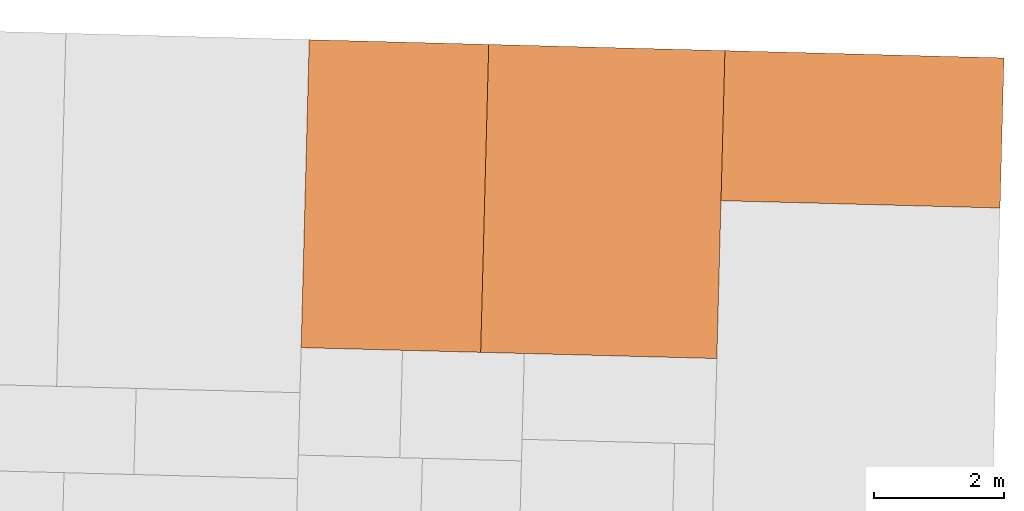
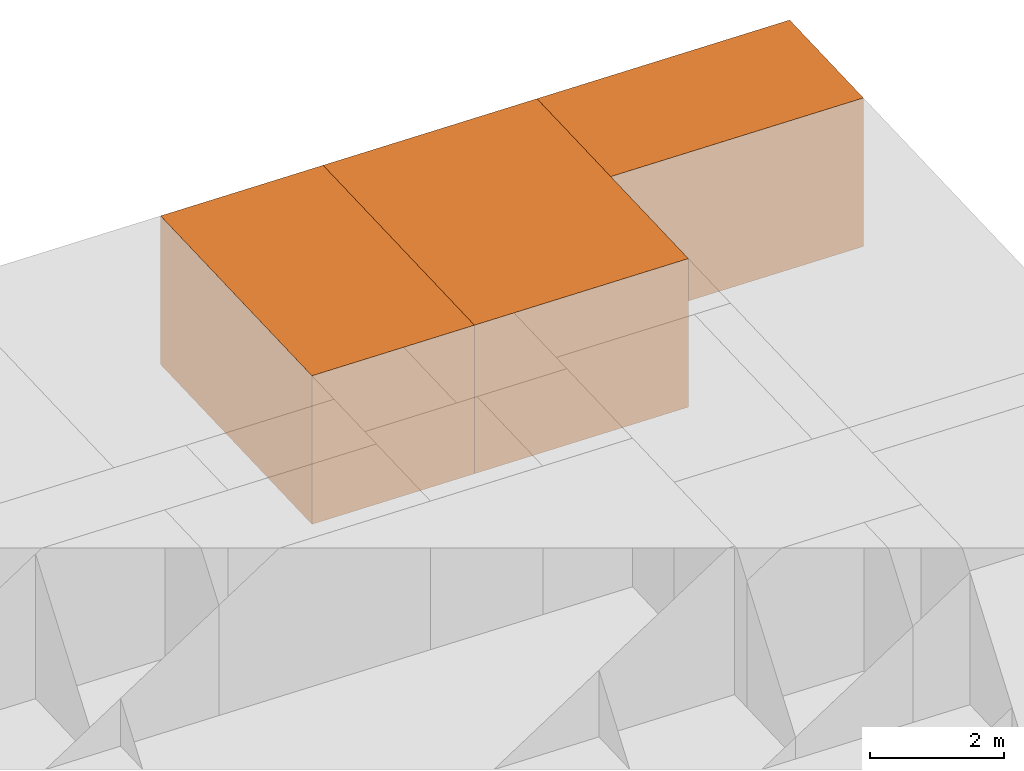
# One storey, part 2 of 2: 3 proxies.
"""IFC2X3 building model written with IfcOpenShell, lengths in metres."""

from ifc_helpers import new_model, entity, si_unit, converted_unit, derived_unit, direction, frame, origin, origin_2d_with_axis, place, context, subcontext, project, spatial, rectangle, extrude, source, transform, mapped, material, type_object, type_shapes, element, save


model = new_model("IFC2X3")

# Units and contexts
model_context = context("Model", 3, precision=1e-05, world=origin(), true_north=direction((-0.999656054706472, -0.0262254130318397)))
body_context = subcontext(model_context, "Body", "Model", "MODEL_VIEW")
ifc_project = project(units=[si_unit("LENGTHUNIT", "METRE"), si_unit("AREAUNIT", "SQUARE_METRE"), si_unit("VOLUMEUNIT", "CUBIC_METRE"), converted_unit("PLANEANGLEUNIT", "DEGREE", entity("IfcRatioMeasure", 0.0174532925199433), si_unit("PLANEANGLEUNIT", "RADIAN"), dimensions=[0, 0, 0, 0, 0, 0, 0]), si_unit("MASSUNIT", "GRAM", prefix="KILO"), derived_unit("MASSDENSITYUNIT", [(si_unit("MASSUNIT", "GRAM", prefix="KILO"), 1), (si_unit("LENGTHUNIT", "METRE"), -3)]), si_unit("TIMEUNIT", "SECOND"), si_unit("FREQUENCYUNIT", "HERTZ"), si_unit("THERMODYNAMICTEMPERATUREUNIT", "DEGREE_CELSIUS"), derived_unit("THERMALTRANSMITTANCEUNIT", [(si_unit("MASSUNIT", "GRAM", prefix="KILO"), 1), (si_unit("THERMODYNAMICTEMPERATUREUNIT", "KELVIN"), -1), (si_unit("TIMEUNIT", "SECOND"), -3)]), derived_unit("VOLUMETRICFLOWRATEUNIT", [(si_unit("LENGTHUNIT", "METRE"), 3), (si_unit("TIMEUNIT", "SECOND"), -1)]), si_unit("ELECTRICCURRENTUNIT", "AMPERE"), si_unit("ELECTRICVOLTAGEUNIT", "VOLT"), si_unit("POWERUNIT", "WATT"), si_unit("FORCEUNIT", "NEWTON", prefix="KILO"), si_unit("ILLUMINANCEUNIT", "LUX"), si_unit("LUMINOUSFLUXUNIT", "LUMEN"), si_unit("LUMINOUSINTENSITYUNIT", "CANDELA"), derived_unit("USERDEFINED", [(si_unit("MASSUNIT", "GRAM", prefix="KILO"), -1), (si_unit("LENGTHUNIT", "METRE"), -2), (si_unit("TIMEUNIT", "SECOND"), 3), (si_unit("LUMINOUSFLUXUNIT", "LUMEN"), 1)]), derived_unit("LINEARVELOCITYUNIT", [(si_unit("LENGTHUNIT", "METRE"), 1), (si_unit("TIMEUNIT", "SECOND"), -1)]), si_unit("PRESSUREUNIT", "PASCAL"), derived_unit("USERDEFINED", [(si_unit("LENGTHUNIT", "METRE"), -2), (si_unit("MASSUNIT", "GRAM", prefix="KILO"), 1), (si_unit("TIMEUNIT", "SECOND"), -2)])], contexts=[model_context])

# Site, building, storey
site_placement = place(None, frame((0.0, 0.0, 0.0), z_axis=(0.0, 0.0, 1.0), x_axis=(-0.0262254130318394, -0.999656054706472, 0.0)))
site = spatial("IfcSite", under=ifc_project, at=site_placement, CompositionType="ELEMENT")
building_placement = place(site_placement, origin())
building = spatial("IfcBuilding", under=site, at=building_placement, CompositionType="ELEMENT")
storey_placement = place(building_placement, frame((0.0, 0.0, 2.7)))
storey = spatial("IfcBuildingStorey", under=building, at=storey_placement, Name="1OG", CompositionType="ELEMENT", Elevation=2.7)

# Proxies
ifc_material_1 = material(Name="004_Balcony")
building_element_proxy_type_1 = type_object("IfcBuildingElementProxyType", PredefinedType="NOTDEFINED", material=ifc_material_1)
shared_shape_1 = source(origin(), body_context, "Body", "SweptSolid", [
    extrude(rectangle(XDim=2.30147058823531, YDim=4.27941176470587, at=origin_2d_with_axis()), frame((0.0, 0.0, 0.0), z_axis=(0.0, 0.0, 1.0), x_axis=(-1.0, 0.0, 0.0)), (0.0, 0.0, 1.0), 2.7),
])
type_shapes(building_element_proxy_type_1, [shared_shape_1])
proxy_1_placement = place(storey_placement, frame((-3.47983786124327, -30.1803742732614, 0.0)))
element("IfcBuildingElementProxy", 1, at=proxy_1_placement, inside=storey, type_object=building_element_proxy_type_1, material=ifc_material_1, Name="Segment_new:S", context=body_context, shape_type="MappedRepresentation", body=[
    mapped(shared_shape_1, transform((0.0, 0.0, 0.0), scale=1.0)),
])
ifc_material_2 = material(Name="001_Bedroom")
building_element_proxy_type_2 = type_object("IfcBuildingElementProxyType", PredefinedType="NOTDEFINED", material=ifc_material_2)
shared_shape_2 = source(origin(), body_context, "Body", "SweptSolid", [
    extrude(rectangle(XDim=4.72205882352941, YDim=3.62205882352943, at=origin_2d_with_axis()), frame((0.0, 0.0, 0.0), z_axis=(0.0, 0.0, 1.0), x_axis=(-1.0, 0.0, 0.0)), (0.0, 0.0, 1.0), 2.7),
])
type_shapes(building_element_proxy_type_2, [shared_shape_2])
proxy_2_placement = place(storey_placement, frame((-2.26954374359621, -34.1311095673791, 0.0)))
element("IfcBuildingElementProxy", 2, at=proxy_2_placement, inside=storey, type_object=building_element_proxy_type_2, material=ifc_material_2, Name="Segment_new:S_Sch", context=body_context, shape_type="MappedRepresentation", body=[
    mapped(shared_shape_2, transform((0.0, 0.0, 0.0), scale=1.0)),
])
building_element_proxy_type_3 = type_object("IfcBuildingElementProxyType", PredefinedType="NOTDEFINED", material=ifc_material_2)
shared_shape_3 = source(origin(), body_context, "Body", "SweptSolid", [
    extrude(rectangle(XDim=4.72205882352941, YDim=2.75294117647059, at=origin_2d_with_axis()), frame((0.0, 0.0, 0.0), z_axis=(0.0, 0.0, 1.0), x_axis=(-1.0, 0.0, 0.0)), (0.0, 0.0, 1.0), 2.7),
])
type_shapes(building_element_proxy_type_3, [shared_shape_3])
proxy_3_placement = place(storey_placement, frame((-2.26954374359622, -37.3186095673791, 0.0)))
element("IfcBuildingElementProxy", 3, at=proxy_3_placement, inside=storey, type_object=building_element_proxy_type_3, material=ifc_material_2, Name="Segment_new:S_Sch", context=body_context, shape_type="MappedRepresentation", body=[
    mapped(shared_shape_3, transform((0.0, 0.0, 0.0), scale=1.0)),
])

save(model, "model.ifc")
